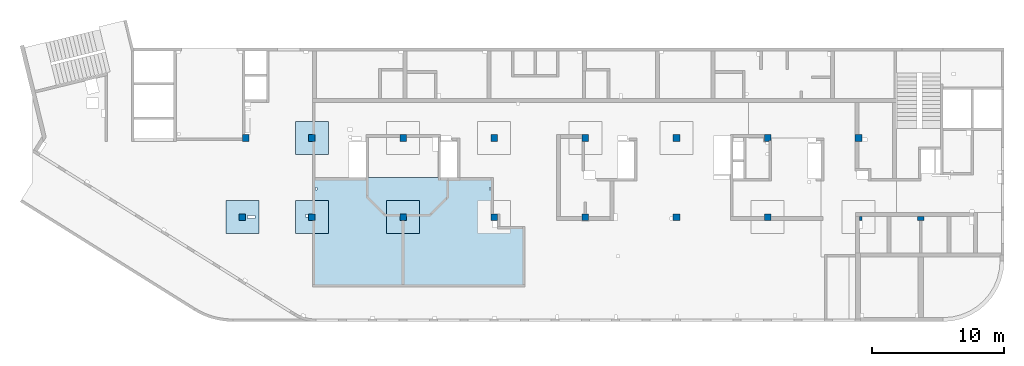
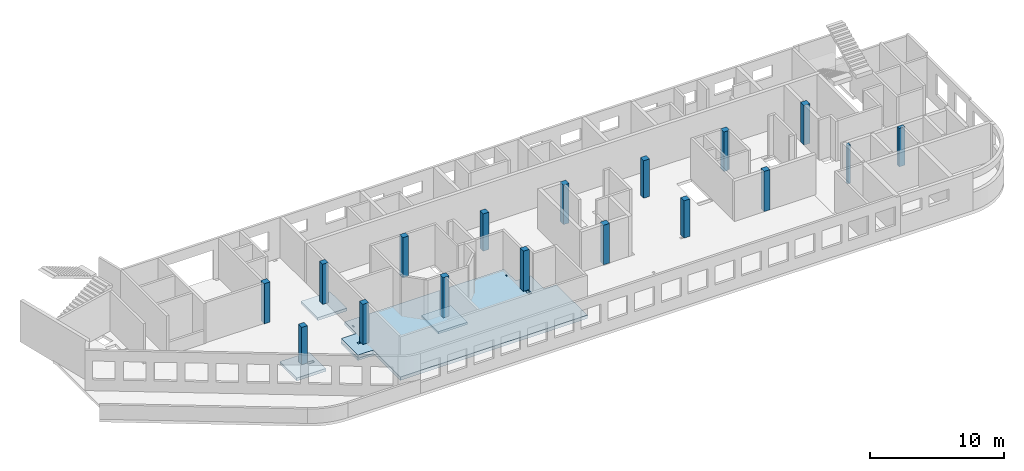
# One storey, part 1 of 10: 17 columns, 5 slabs.
"""IFC4 building model written with IfcOpenShell, lengths in millimetres."""

import ifcopenshell
import ifcopenshell.guid

model = None  # the IFC model being written
_history = None  # IfcOwnerHistory: only IFC2X3 demands one
_inside = {}  # id of a spatial element -> (the spatial element, [elements in it])
_under = {}  # id of a project, library or spatial element -> (it, [spatial elements below it])
_declared = {}  # id of a project -> (the project, [libraries it declares])
_typed = {}  # id of a type object -> (the type object, [elements of that type])
_made_of = {}  # id of a material, layer set ... -> (it, [elements and type objects made of it])


def new_model(schema):
    """Start an empty IFC model of exactly this schema.

    Asked for "IFC4X3", IfcOpenShell would pick the latest addendum, in which some entities
    have other attributes; the version numbers below select the first issue.
    IFC2X3 requires an IfcOwnerHistory on every rooted entity: one is made here for all.
    """
    global model, _history
    if schema == "IFC4X3":
        model = ifcopenshell.file(schema_version=(4, 3, 0, 0))
    else:
        model = ifcopenshell.file(schema=schema)
    _inside.clear()
    _under.clear()
    _declared.clear()
    _typed.clear()
    _made_of.clear()
    _history = None
    if model.schema == "IFC2X3":
        org = make("IfcOrganization", Name="unknown")
        user = make(
            "IfcPersonAndOrganization",
            ThePerson=make("IfcPerson", FamilyName="unknown"),
            TheOrganization=org,
        )
        app = make(
            "IfcApplication",
            ApplicationDeveloper=org,
            Version="unknown",
            ApplicationFullName="unknown",
            ApplicationIdentifier="unknown",
        )
        _history = make(
            "IfcOwnerHistory",
            OwningUser=user,
            OwningApplication=app,
            ChangeAction="ADDED",
            CreationDate=0,
        )
    return model


def make(cls, **values):
    """One entity of the class cls with the attributes given. An attribute that is None is left unset."""
    return model.create_entity(
        cls, **{name: value for name, value in values.items() if value is not None}
    )


def entity(cls, *values):
    """Any entity or typed value of the class cls, its attributes in the order of the schema. None: left unset."""
    e = model.create_entity(cls)
    for i, value in enumerate(values):
        if value is not None:
            e[i] = value
    return e


def rooted(cls, **values):
    """An entity with a GlobalId (a new one), such as an element, a storey or a relation."""
    return make(cls, GlobalId=ifcopenshell.guid.new(), OwnerHistory=_history, **values)


def si_unit(unit_type, name, prefix=None):
    """IfcSIUnit, for example si_unit("LENGTHUNIT", "METRE", prefix="MILLI")."""
    return make("IfcSIUnit", UnitType=unit_type, Prefix=prefix, Name=name)


def converted_unit(unit_type, name, factor, base, dimensions=None, offset=None):
    """IfcConversionBasedUnit, such as the inch: factor (a typed value) times the base unit."""
    return make(
        "IfcConversionBasedUnit"
        if offset is None
        else "IfcConversionBasedUnitWithOffset",
        ConversionOffset=offset,
        Dimensions=None
        if dimensions is None
        else entity("IfcDimensionalExponents", *dimensions),
        UnitType=unit_type,
        Name=name,
        ConversionFactor=make(
            "IfcMeasureWithUnit", ValueComponent=factor, UnitComponent=base
        ),
    )


def derived_unit(unit_type, elements):
    """IfcDerivedUnit: a product of units, each with its exponent."""
    return make(
        "IfcDerivedUnit",
        Elements=[
            make("IfcDerivedUnitElement", Unit=unit, Exponent=power)
            for unit, power in elements
        ],
        UnitType=unit_type,
    )


def assignment(units):
    """IfcUnitAssignment: the units of a project."""
    return None if units is None else make("IfcUnitAssignment", Units=units)


def point(xyz):
    """IfcCartesianPoint."""
    return None if xyz is None else make("IfcCartesianPoint", Coordinates=xyz)


def direction(xyz):
    """IfcDirection."""
    return None if xyz is None else make("IfcDirection", DirectionRatios=xyz)


def frame(location, z_axis=None, x_axis=None):
    """IfcAxis2Placement3D, a coordinate frame: its origin and axes. An axis left out is left unset."""
    return make(
        "IfcAxis2Placement3D",
        Location=point(location),
        Axis=direction(z_axis),
        RefDirection=direction(x_axis),
    )


def origin():
    """The frame at (0, 0, 0) with its axes left unset."""
    return frame((0.0, 0.0, 0.0))


def place(relative_to, where):
    """IfcLocalPlacement: puts the frame where relative to a parent placement (None: the world)."""
    return make(
        "IfcLocalPlacement", PlacementRelTo=relative_to, RelativePlacement=where
    )


def context(
    kind, dimensions, precision=None, world=None, true_north=None, identifier=None
):
    """IfcGeometricRepresentationContext, for example the 3D "Model" context."""
    return make(
        "IfcGeometricRepresentationContext",
        ContextIdentifier=identifier,
        ContextType=kind,
        CoordinateSpaceDimension=dimensions,
        Precision=precision,
        WorldCoordinateSystem=world,
        TrueNorth=true_north,
    )


def subcontext(parent, identifier, kind, view, scale=None):
    """IfcGeometricRepresentationSubContext, for example "Body" below "Model"."""
    return make(
        "IfcGeometricRepresentationSubContext",
        ContextIdentifier=identifier,
        ContextType=kind,
        ParentContext=parent,
        TargetScale=scale,
        TargetView=view,
    )


def project(units=None, contexts=None):
    """IfcProject with its units and contexts."""
    return rooted(
        "IfcProject",
        Name="project",
        RepresentationContexts=contexts,
        UnitsInContext=assignment(units),
    )


def spatial(cls, under=None, at=None, **own):
    """A site, building, storey or space (cls), placed at a placement, below another one or the project."""
    s = rooted(cls, ObjectPlacement=at, **own)
    if under is not None:
        _under.setdefault(under.id(), (under, []))[1].append(s)
    return s


def point_list(points):
    """IfcCartesianPointList2D or 3D."""
    cls = (
        "IfcCartesianPointList2D" if len(points[0]) == 2 else "IfcCartesianPointList3D"
    )
    return make(cls, CoordList=points)


def indexed_curve(points, segments=None, self_intersect=None):
    """IfcIndexedPolyCurve: lines and arcs through numbered points (the first is 1)."""
    return make(
        "IfcIndexedPolyCurve",
        Points=point_list(points),
        Segments=segments,
        SelfIntersect=self_intersect,
    )


def outline(outer, holes=None, kind="AREA"):
    """IfcArbitraryClosedProfileDef: a profile drawn as a closed curve; with holes, ...WithVoids."""
    if holes is None:
        return make("IfcArbitraryClosedProfileDef", ProfileType=kind, OuterCurve=outer)
    return make(
        "IfcArbitraryProfileDefWithVoids",
        ProfileType=kind,
        OuterCurve=outer,
        InnerCurves=holes,
    )


def extrude(swept, where, along, depth):
    """IfcExtrudedAreaSolid: the profile swept, set in the frame where, extruded along a direction by depth."""
    return make(
        "IfcExtrudedAreaSolid",
        SweptArea=swept,
        Position=where,
        ExtrudedDirection=direction(along),
        Depth=depth,
    )


def shape(context_of_items, identifier, shape_type, items):
    """IfcShapeRepresentation: the items that make up one representation, for example the "Body"."""
    return make(
        "IfcShapeRepresentation",
        ContextOfItems=context_of_items,
        RepresentationIdentifier=identifier,
        RepresentationType=shape_type,
        Items=items,
    )


def source(mapping_origin, context_of_items, identifier, shape_type, items):
    """IfcRepresentationMap: a shape defined once, which mapped items show again and again."""
    return make(
        "IfcRepresentationMap",
        MappingOrigin=mapping_origin,
        MappedRepresentation=shape(context_of_items, identifier, shape_type, items),
    )


def transform(
    local_origin,
    x_axis=None,
    y_axis=None,
    z_axis=None,
    scale=None,
    scale2=None,
    scale3=None,
    uniform=True,
):
    """IfcCartesianTransformationOperator3D, or its non-uniform kind. x_axis, y_axis, z_axis: its Axis1, 2, 3."""
    if uniform:
        return make(
            "IfcCartesianTransformationOperator3D",
            Axis1=direction(x_axis),
            Axis2=direction(y_axis),
            LocalOrigin=point(local_origin),
            Scale=scale,
            Axis3=direction(z_axis),
        )
    return make(
        "IfcCartesianTransformationOperator3DnonUniform",
        Axis1=direction(x_axis),
        Axis2=direction(y_axis),
        LocalOrigin=point(local_origin),
        Scale=scale,
        Axis3=direction(z_axis),
        Scale2=scale2,
        Scale3=scale3,
    )


def mapped(mapping_source, mapping_target):
    """IfcMappedItem: shows the shape of a source again, moved by a transform."""
    return make(
        "IfcMappedItem", MappingSource=mapping_source, MappingTarget=mapping_target
    )


def material(Name=None, Category=None):
    """IfcMaterial."""
    return make("IfcMaterial", Name=Name, Category=Category)


def made_of(thing, what):
    """Note that an element or type object is made of a material, layer set ...; save() writes the relation."""
    if what is not None:
        _made_of.setdefault(what.id(), (what, []))[1].append(thing)
    return thing


def type_object(cls, material=None, **own):
    """A type object (cls), such as IfcWallType, which elements share."""
    return made_of(rooted(cls, **own), material)


def type_shapes(of_type, sources):
    """Give a type object the sources (RepresentationMaps) that its elements show as mapped items."""
    of_type.RepresentationMaps = sources


def element(
    cls,
    number,
    at=None,
    inside=None,
    cuts=None,
    type_object=None,
    material=None,
    context=None,
    identifier="Body",
    shape_type=None,
    held_by="IfcProductDefinitionShape",
    body=None,
    shapes=None,
    **own,
):
    """One element of the class cls, such as IfcWall. Its Tag is "e" and its number.

    at: its placement. inside: the storey or other place that contains it. cuts: it is an
    opening in that element (IfcRelVoidsElement). A single representation is given by context,
    identifier, shape_type and body (its items); several are given by shapes. held_by: the class
    of the entity that holds the representations. save() writes the other relations.
    """
    e = rooted(cls, Tag="e%d" % number, ObjectPlacement=at, **own)
    if body is not None:
        shapes = [shape(context, identifier, shape_type, body)]
    if shapes is not None:
        e.Representation = make(held_by, Representations=shapes)
    if inside is not None:
        _inside.setdefault(inside.id(), (inside, []))[1].append(e)
    if cuts is not None:
        rooted(
            "IfcRelVoidsElement", RelatingBuildingElement=cuts, RelatedOpeningElement=e
        )
    if type_object is not None:
        _typed.setdefault(type_object.id(), (type_object, []))[1].append(e)
    return made_of(e, material)


def aggregate(whole, parts):
    """IfcRelAggregates: a whole, such as a stair, and the parts it consists of."""
    return rooted("IfcRelAggregates", RelatingObject=whole, RelatedObjects=parts)


def save(model, path):
    """Write the relations noted so far, then the file.

    IfcRelAggregates (storeys below a building ...), IfcRelContainedInSpatialStructure (elements
    in a storey), IfcRelDefinesByType, IfcRelAssociatesMaterial and IfcRelDeclares: one each for
    every whole, place, type object, material and project.
    """
    for whole, parts in _under.values():
        aggregate(whole, parts)
    for where, things in _inside.values():
        rooted(
            "IfcRelContainedInSpatialStructure",
            RelatedElements=things,
            RelatingStructure=where,
        )
    for kind, things in _typed.values():
        rooted("IfcRelDefinesByType", RelatedObjects=things, RelatingType=kind)
    for what, things in _made_of.values():
        rooted("IfcRelAssociatesMaterial", RelatedObjects=things, RelatingMaterial=what)
    for by, libraries in _declared.values():
        rooted("IfcRelDeclares", RelatingContext=by, RelatedDefinitions=libraries)
    model.write(path)


model = new_model("IFC4")

# Units and contexts
model_context = context("Model", 3, precision=0.01, world=origin(), true_north=direction((6.12303176911189e-17, 1.0)))
plan_context = context("Plan", 3, precision=0.01, world=origin(), true_north=direction((6.12303176911189e-17, 1.0)))
body_context = subcontext(model_context, "Body", "Model", "MODEL_VIEW")
ifc_project = project(units=[si_unit("LENGTHUNIT", "METRE", prefix="MILLI"), si_unit("AREAUNIT", "SQUARE_METRE"), si_unit("VOLUMEUNIT", "CUBIC_METRE"), converted_unit("PLANEANGLEUNIT", "DEGREE", entity("IfcRatioMeasure", 0.0174532925199433), si_unit("PLANEANGLEUNIT", "RADIAN"), dimensions=[0, 0, 0, 0, 0, 0, 0]), si_unit("MASSUNIT", "GRAM", prefix="KILO"), derived_unit("MASSDENSITYUNIT", [(si_unit("MASSUNIT", "GRAM", prefix="KILO"), 1), (si_unit("LENGTHUNIT", "METRE"), -3)]), derived_unit("MOMENTOFINERTIAUNIT", [(si_unit("LENGTHUNIT", "METRE"), 4)]), si_unit("TIMEUNIT", "SECOND"), si_unit("FREQUENCYUNIT", "HERTZ"), si_unit("THERMODYNAMICTEMPERATUREUNIT", "DEGREE_CELSIUS"), derived_unit("THERMALTRANSMITTANCEUNIT", [(si_unit("MASSUNIT", "GRAM", prefix="KILO"), 1), (si_unit("THERMODYNAMICTEMPERATUREUNIT", "KELVIN"), -1), (si_unit("TIMEUNIT", "SECOND"), -3)]), derived_unit("VOLUMETRICFLOWRATEUNIT", [(si_unit("LENGTHUNIT", "METRE"), 3), (si_unit("TIMEUNIT", "SECOND"), -1)]), derived_unit("MASSFLOWRATEUNIT", [(si_unit("MASSUNIT", "GRAM", prefix="KILO"), 1), (si_unit("TIMEUNIT", "SECOND"), -1)]), derived_unit("ROTATIONALFREQUENCYUNIT", [(si_unit("TIMEUNIT", "SECOND"), -1)]), si_unit("ELECTRICCURRENTUNIT", "AMPERE"), si_unit("ELECTRICVOLTAGEUNIT", "VOLT"), si_unit("POWERUNIT", "WATT"), si_unit("FORCEUNIT", "NEWTON", prefix="KILO"), si_unit("ILLUMINANCEUNIT", "LUX"), si_unit("LUMINOUSFLUXUNIT", "LUMEN"), si_unit("LUMINOUSINTENSITYUNIT", "CANDELA"), derived_unit("USERDEFINED", [(si_unit("MASSUNIT", "GRAM", prefix="KILO"), -1), (si_unit("LENGTHUNIT", "METRE"), -2), (si_unit("TIMEUNIT", "SECOND"), 3), (si_unit("LUMINOUSFLUXUNIT", "LUMEN"), 1)]), derived_unit("LINEARVELOCITYUNIT", [(si_unit("LENGTHUNIT", "METRE"), 1), (si_unit("TIMEUNIT", "SECOND"), -1)]), si_unit("PRESSUREUNIT", "PASCAL"), derived_unit("USERDEFINED", [(si_unit("LENGTHUNIT", "METRE"), -2), (si_unit("MASSUNIT", "GRAM", prefix="KILO"), 1), (si_unit("TIMEUNIT", "SECOND"), -2)]), derived_unit("LINEARFORCEUNIT", [(si_unit("MASSUNIT", "GRAM", prefix="KILO"), 1), (si_unit("LENGTHUNIT", "METRE"), 1), (si_unit("TIMEUNIT", "SECOND"), -2), (si_unit("LENGTHUNIT", "METRE"), -1)]), derived_unit("PLANARFORCEUNIT", [(si_unit("MASSUNIT", "GRAM", prefix="KILO"), 1), (si_unit("LENGTHUNIT", "METRE"), 1), (si_unit("TIMEUNIT", "SECOND"), -2), (si_unit("LENGTHUNIT", "METRE"), -2)])], contexts=[model_context, plan_context])

# Site, building, storey
site_placement = place(None, origin())
site = spatial("IfcSite", under=ifc_project, at=site_placement, CompositionType="ELEMENT")
building_placement = place(site_placement, origin())
building = spatial("IfcBuilding", under=site, at=building_placement, CompositionType="ELEMENT")
storey_placement = place(building_placement, frame((0.0, 0.0, 4200.0)))
storey = spatial("IfcBuildingStorey", under=building, at=storey_placement, Name="02", CompositionType="ELEMENT", Elevation=4200.0)

# Columns
ifc_material = material()
column_type_1 = type_object("IfcColumnType", PredefinedType="COLUMN", material=ifc_material)
shared_shape_1 = source(origin(), body_context, "Body", "SweptSolid", [
    extrude(outline(indexed_curve([(-249.999999999999, -249.999999999999), (250.000000000001, -249.999999999999), (250.000000000001, 249.999999999999), (-249.999999999999, 249.999999999999), (-249.999999999999, -249.999999999999)], self_intersect=False)), frame((15900.0, 7700.0, 4050.0), z_axis=(0.0, 0.0, 1.0), x_axis=(0.0, -1.0, 0.0)), (0.0, 0.0, 1.0), 3400.0),
])
type_shapes(column_type_1, [shared_shape_1])
placement_1 = place(storey_placement, frame((0.0, 0.0, -4200.0)))
element("IfcColumn", 1, at=placement_1, inside=storey, type_object=column_type_1, PredefinedType="COLUMN", context=body_context, shape_type="MappedRepresentation", body=[
    mapped(shared_shape_1, transform((0.0, 0.0, 0.0), scale=1.0)),
])
column_type_2 = type_object("IfcColumnType", PredefinedType="COLUMN", material=ifc_material)
shared_shape_2 = source(origin(), body_context, "Body", "SweptSolid", [
    extrude(outline(indexed_curve([(-249.999999999999, -249.999999999999), (250.000000000001, -249.999999999999), (250.000000000001, 249.999999999999), (-249.999999999999, 249.999999999999), (-249.999999999999, -249.999999999999)], self_intersect=False)), frame((21170.0, 7700.0, 4050.0), z_axis=(0.0, 0.0, 1.0), x_axis=(0.0, -1.0, 0.0)), (0.0, 0.0, 1.0), 3650.0),
])
type_shapes(column_type_2, [shared_shape_2])
element("IfcColumn", 2, at=placement_1, inside=storey, type_object=column_type_2, PredefinedType="COLUMN", context=body_context, shape_type="MappedRepresentation", body=[
    mapped(shared_shape_2, transform((0.0, 0.0, 0.0), scale=1.0)),
])
column_type_3 = type_object("IfcColumnType", PredefinedType="COLUMN", material=ifc_material)
shared_shape_3 = source(origin(), body_context, "Body", "SweptSolid", [
    extrude(outline(indexed_curve([(-249.999999999999, -249.999999999999), (249.999999999999, -249.999999999999), (249.999999999999, 249.999999999999), (-249.999999999999, 249.999999999999), (-249.999999999999, -249.999999999999)], self_intersect=False)), frame((21170.0, 13700.0, 4050.0), z_axis=(0.0, 0.0, 1.0), x_axis=(0.0, -1.0, 0.0)), (0.0, 0.0, 1.0), 3650.0),
])
type_shapes(column_type_3, [shared_shape_3])
element("IfcColumn", 3, at=placement_1, inside=storey, type_object=column_type_3, PredefinedType="COLUMN", context=body_context, shape_type="MappedRepresentation", body=[
    mapped(shared_shape_3, transform((0.0, 0.0, 0.0), scale=1.0)),
])
column_type_4 = type_object("IfcColumnType", PredefinedType="COLUMN", material=ifc_material)
shared_shape_4 = source(origin(), body_context, "Body", "SweptSolid", [
    extrude(outline(indexed_curve([(-249.999999999999, -249.999999999999), (249.999999999999, -249.999999999999), (249.999999999999, 249.999999999999), (-249.999999999999, 249.999999999999), (-249.999999999999, -249.999999999999)], self_intersect=False)), frame((28070.0, 13700.0, 4050.0), z_axis=(0.0, 0.0, 1.0), x_axis=(0.0, -1.0, 0.0)), (0.0, 0.0, 1.0), 3650.0),
])
type_shapes(column_type_4, [shared_shape_4])
element("IfcColumn", 4, at=placement_1, inside=storey, type_object=column_type_4, PredefinedType="COLUMN", context=body_context, shape_type="MappedRepresentation", body=[
    mapped(shared_shape_4, transform((0.0, 0.0, 0.0), scale=1.0)),
])
column_type_5 = type_object("IfcColumnType", PredefinedType="COLUMN", material=ifc_material)
shared_shape_5 = source(origin(), body_context, "Body", "SweptSolid", [
    extrude(outline(indexed_curve([(-249.999999999999, -249.999999999999), (250.000000000001, -249.999999999999), (249.999999999999, 249.999999999999), (-250.000000000001, 249.999999999999), (-249.999999999999, -249.999999999999)], self_intersect=False)), frame((28070.0, 7700.0, 4050.0), z_axis=(0.0, 0.0, 1.0), x_axis=(0.0, -1.0, 0.0)), (0.0, 0.0, 1.0), 3650.0),
])
type_shapes(column_type_5, [shared_shape_5])
element("IfcColumn", 5, at=placement_1, inside=storey, type_object=column_type_5, PredefinedType="COLUMN", context=body_context, shape_type="MappedRepresentation", body=[
    mapped(shared_shape_5, transform((0.0, 0.0, 0.0), scale=1.0)),
])
column_type_6 = type_object("IfcColumnType", PredefinedType="COLUMN", material=ifc_material)
shared_shape_6 = source(origin(), body_context, "Body", "SweptSolid", [
    extrude(outline(indexed_curve([(-249.999999999999, -249.999999999999), (250.000000000001, -249.999999999999), (250.000000000001, 249.999999999999), (-249.999999999999, 249.999999999999), (-249.999999999999, -249.999999999999)], self_intersect=False)), frame((34970.0, 7700.0, 4050.0), z_axis=(0.0, 0.0, 1.0), x_axis=(0.0, -1.0, 0.0)), (0.0, 0.0, 1.0), 3650.0),
])
type_shapes(column_type_6, [shared_shape_6])
element("IfcColumn", 6, at=placement_1, inside=storey, type_object=column_type_6, PredefinedType="COLUMN", context=body_context, shape_type="MappedRepresentation", body=[
    mapped(shared_shape_6, transform((0.0, 0.0, 0.0), scale=1.0)),
])
column_type_7 = type_object("IfcColumnType", PredefinedType="COLUMN", material=ifc_material)
shared_shape_7 = source(origin(), body_context, "Body", "SweptSolid", [
    extrude(outline(indexed_curve([(-249.999999999999, -249.999999999999), (249.999999999999, -249.999999999999), (249.999999999999, 249.999999999999), (-249.999999999999, 249.999999999999), (-249.999999999999, -249.999999999999)], self_intersect=False)), frame((34970.0, 13700.0, 4050.0), z_axis=(0.0, 0.0, 1.0), x_axis=(0.0, -1.0, 0.0)), (0.0, 0.0, 1.0), 3400.0),
])
type_shapes(column_type_7, [shared_shape_7])
element("IfcColumn", 7, at=placement_1, inside=storey, type_object=column_type_7, PredefinedType="COLUMN", context=body_context, shape_type="MappedRepresentation", body=[
    mapped(shared_shape_7, transform((0.0, 0.0, 0.0), scale=1.0)),
])
column_type_8 = type_object("IfcColumnType", PredefinedType="COLUMN", material=ifc_material)
shared_shape_8 = source(origin(), body_context, "Body", "SweptSolid", [
    extrude(outline(indexed_curve([(-249.999999999999, -250.000000000004), (249.999999999999, -250.000000000004), (249.999999999999, 249.999999999995), (-249.999999999999, 250.000000000004), (-249.999999999999, -250.000000000004)], self_intersect=False)), frame((41870.0, 13700.0, 4050.0), z_axis=(0.0, 0.0, 1.0), x_axis=(0.0, -1.0, 0.0)), (0.0, 0.0, 1.0), 3600.0),
])
type_shapes(column_type_8, [shared_shape_8])
element("IfcColumn", 8, at=placement_1, inside=storey, type_object=column_type_8, PredefinedType="COLUMN", context=body_context, shape_type="MappedRepresentation", body=[
    mapped(shared_shape_8, transform((0.0, 0.0, 0.0), scale=1.0)),
])
column_type_9 = type_object("IfcColumnType", PredefinedType="COLUMN", material=ifc_material)
shared_shape_9 = source(origin(), body_context, "Body", "SweptSolid", [
    extrude(outline(indexed_curve([(-249.999999999999, -250.000000000004), (250.000000000001, -250.000000000004), (249.999999999999, 249.999999999995), (-250.000000000001, 250.000000000004), (-249.999999999999, -250.000000000004)], self_intersect=False)), frame((41870.0, 7700.0, 4050.0), z_axis=(0.0, 0.0, 1.0), x_axis=(0.0, -1.0, 0.0)), (0.0, 0.0, 1.0), 3600.0),
])
type_shapes(column_type_9, [shared_shape_9])
element("IfcColumn", 9, at=placement_1, inside=storey, type_object=column_type_9, PredefinedType="COLUMN", context=body_context, shape_type="MappedRepresentation", body=[
    mapped(shared_shape_9, transform((0.0, 0.0, 0.0), scale=1.0)),
])
column_type_10 = type_object("IfcColumnType", PredefinedType="COLUMN", material=ifc_material)
shared_shape_10 = source(origin(), body_context, "Body", "SweptSolid", [
    extrude(outline(indexed_curve([(-249.999999999999, -250.000000000004), (250.000000000001, -250.000000000004), (250.000000000001, 249.999999999995), (-249.999999999999, 250.000000000004), (-249.999999999999, -250.000000000004)], self_intersect=False)), frame((48770.0, 7700.0, 4050.0), z_axis=(0.0, 0.0, 1.0), x_axis=(0.0, -1.0, 0.0)), (0.0, 0.0, 1.0), 3400.0),
])
type_shapes(column_type_10, [shared_shape_10])
element("IfcColumn", 10, at=placement_1, inside=storey, type_object=column_type_10, PredefinedType="COLUMN", context=body_context, shape_type="MappedRepresentation", body=[
    mapped(shared_shape_10, transform((0.0, 0.0, 0.0), scale=1.0)),
])
column_type_11 = type_object("IfcColumnType", PredefinedType="COLUMN", material=ifc_material)
shared_shape_11 = source(origin(), body_context, "Body", "SweptSolid", [
    extrude(outline(indexed_curve([(-249.999999999999, -250.000000000004), (249.999999999999, -250.000000000004), (249.999999999999, 249.999999999995), (-249.999999999999, 250.000000000004), (-249.999999999999, -250.000000000004)], self_intersect=False)), frame((48770.0, 13700.0, 4050.0), z_axis=(0.0, 0.0, 1.0), x_axis=(0.0, -1.0, 0.0)), (0.0, 0.0, 1.0), 3400.0),
])
type_shapes(column_type_11, [shared_shape_11])
element("IfcColumn", 11, at=placement_1, inside=storey, type_object=column_type_11, PredefinedType="COLUMN", context=body_context, shape_type="MappedRepresentation", body=[
    mapped(shared_shape_11, transform((0.0, 0.0, 0.0), scale=1.0)),
])
column_type_12 = type_object("IfcColumnType", PredefinedType="COLUMN", material=ifc_material)
shared_shape_12 = source(origin(), body_context, "Body", "SweptSolid", [
    extrude(outline(indexed_curve([(-316.666666666675, -283.333333333321), (183.333333333324, -283.333333333321), (183.333333333324, 66.6666666666602), (133.333333333353, 66.6666666666602), (133.333333333353, 216.666666666687), (-316.666666666675, 216.666666666687), (-316.666666666675, -283.333333333321)], self_intersect=False)), frame((55703.33, 13633.33, 4050.0), z_axis=(0.0, 0.0, 1.0), x_axis=(0.0, -1.0, 0.0)), (0.0, 0.0, 1.0), 3600.0),
])
type_shapes(column_type_12, [shared_shape_12])
element("IfcColumn", 12, at=placement_1, inside=storey, type_object=column_type_12, PredefinedType="COLUMN", context=body_context, shape_type="MappedRepresentation", body=[
    mapped(shared_shape_12, transform((0.0, 0.0, 0.0), scale=1.0)),
])
column_type_13 = type_object("IfcColumnType", PredefinedType="COLUMN", material=ifc_material)
shared_shape_13 = source(origin(), body_context, "Body", "SweptSolid", [
    extrude(outline(indexed_curve([(-249.999999999999, -250.000000000004), (250.000000000001, -250.000000000004), (249.999999999999, 249.999999999995), (-250.000000000001, 250.000000000004), (-249.999999999999, -250.000000000004)], self_intersect=False)), frame((55670.0, 7700.0, 4050.0), z_axis=(0.0, 0.0, 1.0), x_axis=(0.0, -1.0, 0.0)), (0.0, 0.0, 1.0), 3650.0),
])
type_shapes(column_type_13, [shared_shape_13])
element("IfcColumn", 13, at=placement_1, inside=storey, type_object=column_type_13, PredefinedType="COLUMN", context=body_context, shape_type="MappedRepresentation", body=[
    mapped(shared_shape_13, transform((0.0, 0.0, 0.0), scale=1.0)),
])
column_type_14 = type_object("IfcColumnType", PredefinedType="COLUMN", material=ifc_material)
shared_shape_14 = source(origin(), body_context, "Body", "SweptSolid", [
    extrude(outline(indexed_curve([(-149.99999999991, -99.9999999999946), (149.99999999991, -99.9999999999946), (149.99999999991, 100.000000000003), (-149.99999999991, 100.000000000012), (-149.99999999991, -99.9999999999946)], self_intersect=False)), frame((62720.0, 7600.0, 4050.0), z_axis=(0.0, 0.0, 1.0), x_axis=(0.0, -1.0, 0.0)), (0.0, 0.0, 1.0), 3500.0),
])
type_shapes(column_type_14, [shared_shape_14])
element("IfcColumn", 14, at=placement_1, inside=storey, type_object=column_type_14, PredefinedType="COLUMN", context=body_context, shape_type="MappedRepresentation", body=[
    mapped(shared_shape_14, transform((0.0, 0.0, 0.0), scale=1.0)),
])
column_type_15 = type_object("IfcColumnType", PredefinedType="COLUMN", material=ifc_material)
shared_shape_15 = source(origin(), body_context, "Body", "SweptSolid", [
    extrude(outline(indexed_curve([(-249.999999999999, -262.500000000001), (249.999999999999, -262.500000000001), (249.999999999999, 262.500000000001), (-249.999999999999, 262.500000000001), (-249.999999999999, -262.500000000001)], self_intersect=False)), frame((62557.5, 13700.0, 4050.0), z_axis=(0.0, 0.0, 1.0), x_axis=(0.0, -1.0, 0.0)), (0.0, 0.0, 1.0), 3600.0),
])
type_shapes(column_type_15, [shared_shape_15])
element("IfcColumn", 15, at=placement_1, inside=storey, type_object=column_type_15, PredefinedType="COLUMN", context=body_context, shape_type="MappedRepresentation", body=[
    mapped(shared_shape_15, transform((0.0, 0.0, 0.0), scale=1.0)),
])
column_type_16 = type_object("IfcColumnType", PredefinedType="COLUMN", material=ifc_material)
shared_shape_16 = source(origin(), body_context, "Body", "SweptSolid", [
    extrude(outline(indexed_curve([(-249.999999999999, -249.999999999999), (249.999999999999, -249.999999999999), (249.999999999999, 249.999999999999), (-249.999999999999, 249.999999999999), (-249.999999999999, -249.999999999999)], self_intersect=False)), frame((16150.0, 13700.0, 4050.0), z_axis=(0.0, 0.0, 1.0), x_axis=(0.0, -1.0, 0.0)), (0.0, 0.0, 1.0), 3650.0),
])
type_shapes(column_type_16, [shared_shape_16])
element("IfcColumn", 16, at=placement_1, inside=storey, type_object=column_type_16, PredefinedType="COLUMN", context=body_context, shape_type="MappedRepresentation", body=[
    mapped(shared_shape_16, transform((0.0, 0.0, 0.0), scale=1.0)),
])
column_type_17 = type_object("IfcColumnType", PredefinedType="COLUMN", material=ifc_material)
shared_shape_17 = source(origin(), body_context, "Body", "SweptSolid", [
    extrude(outline(indexed_curve([(-149.999999999912, -249.999999999995), (149.999999999911, -249.999999999995), (149.999999999911, 250.000000000004), (-149.999999999911, 250.000000000012), (-149.999999999912, -249.999999999995)], self_intersect=False)), frame((67270.0, 7600.0, 4050.0), z_axis=(0.0, 0.0, 1.0), x_axis=(0.0, -1.0, 0.0)), (0.0, 0.0, 1.0), 3500.0),
])
type_shapes(column_type_17, [shared_shape_17])
element("IfcColumn", 17, at=placement_1, inside=storey, type_object=column_type_17, PredefinedType="COLUMN", context=body_context, shape_type="MappedRepresentation", body=[
    mapped(shared_shape_17, transform((0.0, 0.0, 0.0), scale=1.0)),
])

# Slabs
slab_type_1 = type_object("IfcSlabType", Name=":ADSK_ 25_300", PredefinedType="FLOOR", material=ifc_material)
placement_2 = place(storey_placement, origin())
element("IfcSlab", 18, at=placement_2, inside=storey, type_object=slab_type_1, material=ifc_material, Name=":ADSK_ 25_300", ObjectType=":ADSK_ 25_300", PredefinedType="FLOOR", context=body_context, shape_type="SweptSolid", body=[
    extrude(outline(indexed_curve([(-722.500000000044, -8448.74999999999), (1777.49999999996, -8448.74999999999), (1777.49999999996, -7148.75), (5827.50000000003, -7148.75), (5827.50000000006, 8926.24999999999), (1227.50000000005, 8926.25), (1227.50000000005, 7851.25), (-722.500000000003, 7851.25), (-722.500000000005, 6551.25), (-2462.49999999999, 6551.25), (-2462.5, 3801.24999999999), (-2462.5, 2531.25000000001), (-2462.50000000001, -3118.75), (-2462.50000000001, -4378.75000000001), (-2462.50000000001, -7148.74999999999), (-722.500000000042, -7148.75), (-722.500000000044, -8448.74999999999)], self_intersect=False), holes=[indexed_curve([(327.499999999815, -7498.75), (527.499999999955, -7498.75), (527.499999999955, -7698.75000000001), (327.499999999815, -7698.75000000001), (327.499999999815, -7498.75)], self_intersect=False), indexed_curve([(-1742.50000000021, 6331.24999999997), (-1542.5000000002, 6331.24999999997), (-1542.5000000002, 6231.24999999997), (-1742.50000000021, 6231.24999999997), (-1742.50000000021, 6331.24999999997)], self_intersect=False), indexed_curve([(827.499999999798, 6801.24999999999), (1287.4999999998, 6801.24999999999), (1287.4999999998, 6481.24999999999), (827.499999999798, 6481.24999999999), (827.499999999798, 6801.24999999999)], self_intersect=False), indexed_curve([(-1742.50000000018, -6828.75000000001), (-1542.50000000018, -6828.75), (-1542.50000000018, -6928.75000000002), (-1742.50000000018, -6928.75000000002), (-1742.50000000018, -6828.75000000001)], self_intersect=False)]), frame((28368.75, 8227.5, -450.0), z_axis=(0.0, 0.0, 1.0), x_axis=(0.0, -1.0, 0.0)), (0.0, 0.0, 1.0), 300.0),
])
slab_type_2 = type_object("IfcSlabType", Name=":ADSK_ 25_200", PredefinedType="FLOOR", material=ifc_material)
element("IfcSlab", 19, at=placement_2, inside=storey, type_object=slab_type_2, material=ifc_material, Name=":ADSK_ 25_200", ObjectType=":ADSK_ 25_200", PredefinedType="FLOOR", context=body_context, shape_type="SweptSolid", body=[
    extrude(outline(indexed_curve([(-1250.0, -1250.0), (1250.0, -1250.0), (1250.0, 1250.0), (-1250.0, 1250.0), (-1250.0, -1250.0)], self_intersect=False), holes=[indexed_curve([(300.000000000001, -200.000000000139), (300.000000000001, 1.08286712929839e-12), (500.000000000016, 1.08286712929839e-12), (500.000000000016, -200.000000000139), (300.000000000001, -200.000000000139)], self_intersect=False)]), frame((21170.0, 7700.0, -650.0), z_axis=(0.0, 0.0, 1.0), x_axis=(-1.0, 0.0, 0.0)), (0.0, 0.0, 1.0), 200.0),
])
slab_type_3 = type_object("IfcSlabType", Name=":ADSK_ 25_200", PredefinedType="FLOOR", material=ifc_material)
element("IfcSlab", 20, at=placement_2, inside=storey, type_object=slab_type_3, material=ifc_material, Name=":ADSK_ 25_200", ObjectType=":ADSK_ 25_200", PredefinedType="FLOOR", context=body_context, shape_type="SweptSolid", body=[
    extrude(outline(indexed_curve([(-1250.0, -1250.0), (1250.0, -1250.0), (1250.0, 1250.0), (-1250.0, 1250.0), (-1250.0, -1250.0)], self_intersect=False)), frame((28070.0, 7700.0, -450.0), z_axis=(0.0, 0.0, -1.0), x_axis=(0.0, 1.0, 0.0)), (0.0, 0.0, 1.0), 200.0),
])
slab_type_4 = type_object("IfcSlabType", Name=":ADSK_ 25_250", PredefinedType="FLOOR", material=ifc_material)
element("IfcSlab", 21, at=placement_2, inside=storey, type_object=slab_type_4, material=ifc_material, Name=":ADSK_ 25_250", ObjectType=":ADSK_ 25_250", PredefinedType="FLOOR", context=body_context, shape_type="SweptSolid", body=[
    extrude(outline(indexed_curve([(-1250.0, -1250.0), (1250.0, -1250.0), (1250.0, 1250.0), (-1250.0, 1250.0), (-1250.0, -1250.0)], self_intersect=False), holes=[indexed_curve([(-949.999999999979, -150.000000000118), (-949.999999999979, 99.9999999998776), (-389.999999999968, 99.9999999998776), (-389.999999999968, -150.000000000118), (-949.999999999979, -150.000000000118)], self_intersect=False)]), frame((15900.0, 7700.0, -650.0), z_axis=(0.0, 0.0, 1.0), x_axis=(-1.0, 0.0, 0.0)), (0.0, 0.0, 1.0), 250.0),
])
slab_type_5 = type_object("IfcSlabType", Name=":ADSK_ 25_250", PredefinedType="FLOOR", material=ifc_material)
element("IfcSlab", 22, at=placement_2, inside=storey, type_object=slab_type_5, material=ifc_material, Name=":ADSK_ 25_250", ObjectType=":ADSK_ 25_250", PredefinedType="FLOOR", context=body_context, shape_type="SweptSolid", body=[
    extrude(outline(indexed_curve([(-1250.0, -1250.0), (1250.0, -1250.0), (1250.0, 1250.0), (-1250.0, 1250.0), (-1250.0, -1250.0)], self_intersect=False)), frame((21170.0, 13700.0, -400.0), z_axis=(0.0, 0.0, -1.0), x_axis=(0.0, 1.0, 0.0)), (0.0, 0.0, 1.0), 250.0),
])

save(model, "model.ifc")
